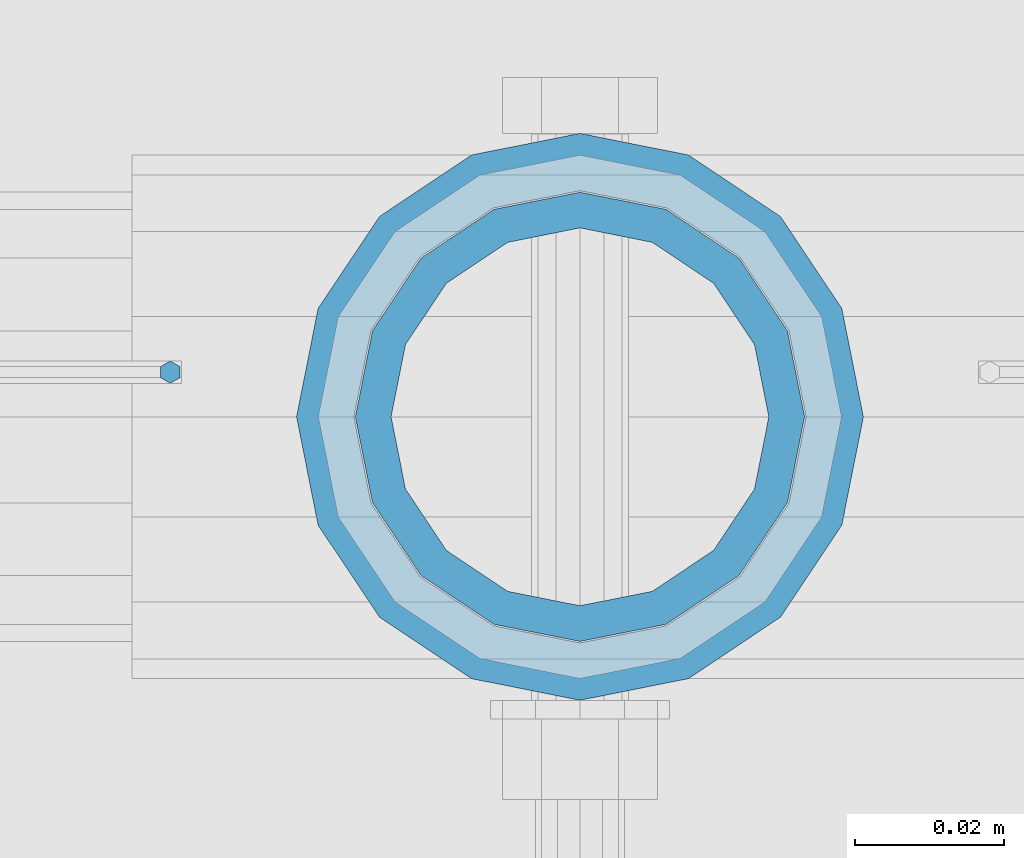
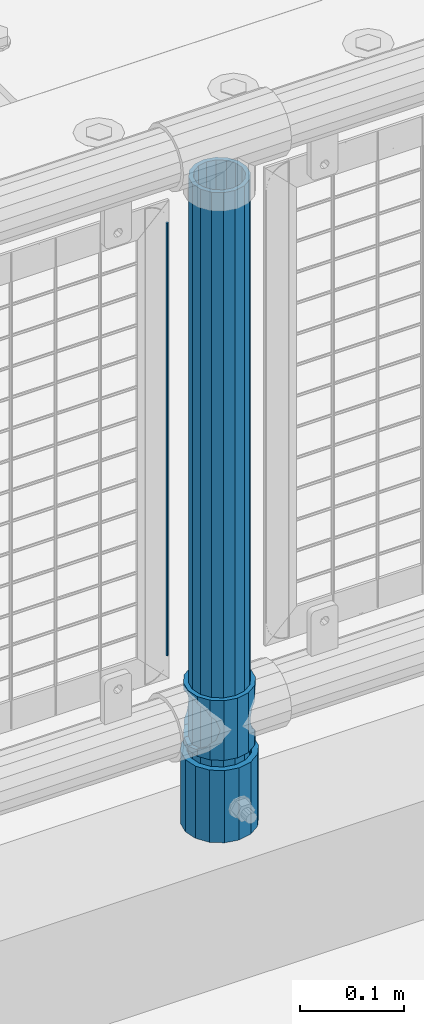
# One storey, part 67 of 208: 4 columns.
"""IFC2X3 building model written with IfcOpenShell, lengths in millimetres."""

from ifc_helpers import new_model, si_unit, frame, origin_with_axes, place, context, subcontext, project, spatial, faceted_brep, material, type_object, element, save


model = new_model("IFC2X3")

# Units and contexts
model_context = context("Model", 3, precision=1e-05, world=origin_with_axes())
body_context = subcontext(model_context, "Body", "Model", "MODEL_VIEW")
ifc_project = project(units=[si_unit("LENGTHUNIT", "METRE", prefix="MILLI"), si_unit("AREAUNIT", "SQUARE_METRE"), si_unit("VOLUMEUNIT", "CUBIC_METRE"), si_unit("MASSUNIT", "GRAM", prefix="KILO"), si_unit("TIMEUNIT", "SECOND"), si_unit("PLANEANGLEUNIT", "RADIAN"), si_unit("SOLIDANGLEUNIT", "STERADIAN"), si_unit("THERMODYNAMICTEMPERATUREUNIT", "DEGREE_CELSIUS"), si_unit("LUMINOUSINTENSITYUNIT", "LUMEN")], contexts=[model_context])

# Site, building, storey
site_placement = place(None, origin_with_axes())
site = spatial("IfcSite", under=ifc_project, at=site_placement, CompositionType="ELEMENT")
building_placement = place(site_placement, origin_with_axes())
building = spatial("IfcBuilding", under=site, at=building_placement, Name="Standard", CompositionType="ELEMENT")
storey_placement = place(building_placement, origin_with_axes())
storey = spatial("IfcBuildingStorey", under=building, at=storey_placement, Name="Undefined", CompositionType="ELEMENT", Elevation=0.0)

# Columns
ifc_material_1 = material()
column_type_1 = type_object("IfcColumnType", PredefinedType="NOTDEFINED")
column_1_placement = place(storey_placement, frame((-35429.0, 4664.5, 168.02), z_axis=(0.0, 1.0, 0.0), x_axis=(0.0, 0.0, 1.0)))
element("IfcColumn", 1, at=column_1_placement, inside=storey, type_object=column_type_1, material=ifc_material_1, context=body_context, shape_type="Brep", body=[
    faceted_brep([(0.0, -31.75, 0.0), (0.0, -29.3331751572332, 12.1501989775916), (85.0, -29.3331751572332, 12.1501989775916), (85.0, -31.75, 0.0), (0.0, -22.4506403026717, 22.4506403026726), (85.0, -22.4506403026717, 22.4506403026726), (0.0, -12.1501989775934, 29.3331751572332), (85.0, -12.1501989775934, 29.3331751572332), (0.0, 0.0, 31.75), (85.0, 0.0, 31.75), (0.0, 12.1501989775934, 29.3331751572332), (85.0, 12.1501989775934, 29.3331751572332), (0.0, 22.4506403026717, 22.4506403026726), (85.0, 22.4506403026717, 22.4506403026726), (0.0, 29.3331751572332, 12.1501989775916), (85.0, 29.3331751572332, 12.1501989775916), (0.0, 31.75, 0.0), (85.0, 31.75, 0.0), (0.0, 29.3331751572332, -12.1501989775916), (85.0, 29.3331751572332, -12.1501989775916), (0.0, 22.4506403026717, -22.4506403026726), (85.0, 22.4506403026717, -22.4506403026726), (0.0, 12.1501989775934, -29.3331751572332), (85.0, 12.1501989775934, -29.3331751572332), (0.0, 0.0, -31.75), (85.0, 0.0, -31.75), (0.0, -12.1501989775934, -29.3331751572332), (85.0, -12.1501989775934, -29.3331751572332), (0.0, -22.4506403026717, -22.4506403026726), (85.0, -22.4506403026717, -22.4506403026726), (0.0, -29.3331751572332, -12.1501989775916), (85.0, -29.3331751572332, -12.1501989775916), (0.0, -38.0499999999993, 0.0), (0.0, -35.1536162120537, -14.5611046014919), (85.0, -35.1536162120537, -14.5611046014919), (85.0, -38.0499999999993, 0.0), (0.0, -26.9054130241493, -26.9054130241484), (85.0, -26.9054130241493, -26.9054130241484), (0.0, -14.5611046014928, -35.1536162120547), (85.0, -14.5611046014928, -35.1536162120547), (0.0, 0.0, -38.0500000000002), (85.0, 0.0, -38.0500000000002), (0.0, 14.5611046014928, -35.1536162120547), (85.0, 14.5611046014928, -35.1536162120547), (0.0, 26.9054130241493, -26.9054130241484), (85.0, 26.9054130241493, -26.9054130241484), (0.0, 35.1536162120537, -14.5611046014919), (85.0, 35.1536162120537, -14.5611046014919), (0.0, 38.0499999999993, 0.0), (85.0, 38.0499999999993, 0.0), (0.0, 35.1536162120537, 14.5611046014919), (85.0, 35.1536162120537, 14.5611046014919), (0.0, 26.9054130241493, 26.9054130241484), (85.0, 26.9054130241493, 26.9054130241484), (0.0, 14.5611046014928, 35.1536162120547), (85.0, 14.5611046014928, 35.1536162120547), (0.0, 0.0, 38.0500000000002), (85.0, 0.0, 38.0500000000002), (0.0, -14.5611046014928, 35.1536162120547), (85.0, -14.5611046014928, 35.1536162120547), (0.0, -26.9054130241493, 26.9054130241484), (85.0, -26.9054130241493, 26.9054130241484), (0.0, -35.1536162120537, 14.5611046014919), (85.0, -35.1536162120537, 14.5611046014919)], [[[0, 1, 2, 3]], [[1, 4, 5, 2]], [[4, 6, 7, 5]], [[6, 8, 9, 7]], [[8, 10, 11, 9]], [[10, 12, 13, 11]], [[12, 14, 15, 13]], [[14, 16, 17, 15]], [[16, 18, 19, 17]], [[18, 20, 21, 19]], [[20, 22, 23, 21]], [[22, 24, 25, 23]], [[24, 26, 27, 25]], [[26, 28, 29, 27]], [[28, 30, 31, 29]], [[30, 0, 3, 31]], [[32, 33, 34, 35]], [[33, 36, 37, 34]], [[36, 38, 39, 37]], [[38, 40, 41, 39]], [[40, 42, 43, 41]], [[42, 44, 45, 43]], [[44, 46, 47, 45]], [[46, 48, 49, 47]], [[48, 50, 51, 49]], [[50, 52, 53, 51]], [[52, 54, 55, 53]], [[54, 56, 57, 55]], [[56, 58, 59, 57]], [[58, 60, 61, 59]], [[60, 62, 63, 61]], [[62, 32, 35, 63]], [[37, 39, 41, 43, 45, 47, 49, 51, 53, 55, 57, 59, 61, 63, 35, 34], [5, 7, 9, 11, 13, 15, 17, 19, 21, 23, 25, 27, 29, 31, 3, 2]], [[62, 60, 58, 56, 54, 52, 50, 48, 46, 44, 42, 40, 38, 36, 33, 32], [30, 28, 26, 24, 22, 20, 18, 16, 14, 12, 10, 8, 6, 4, 1, 0]]]),
])
ifc_material_2 = material(Name="Misc_Undefined")
column_type_2 = type_object("IfcColumnType", PredefinedType="NOTDEFINED")
column_2_placement = place(storey_placement, frame((-35429.0, 4664.5, 263.02), z_axis=(-1.0, 0.0, 0.0), x_axis=(0.0, 0.0, 1.0)))
element("IfcColumn", 2, at=column_2_placement, inside=storey, type_object=column_type_2, material=ifc_material_2, context=body_context, shape_type="Brep", body=[
    faceted_brep([(63.1897438117172, 11.6144421722802, -32.8397438117245), (63.1897438117172, 11.6144421722802, -28.0397438117143), (56.6106908090114, 21.4606908090118, -21.4606908090136), (56.6106908090114, 21.4606908090118, -27.1226768591077), (61.962379517676, 13.4513226476329, -32.4743655677739), (46.7644421722801, 28.0397438117179, -11.6144421722784), (46.7644421722801, 28.0397438117179, -20.0882031229921), (51.531042408003, 24.8548033587067, -24.8548033587067), (35.1500000000015, 30.35, 0.0), (35.1499999999996, 30.3500000000004, -16.6306603983685), (23.5355578277192, 28.0397438117179, -11.6144421722784), (23.5355578277192, 28.0397438117179, -20.0882031229921), (18.7689575919962, 24.8548033587067, -24.8548033587067), (13.6893091909879, 21.4606908090118, -21.4606908090136), (13.6893091909879, 21.4606908090118, -27.1226768591077), (8.33762048232325, 13.4513226476329, -32.4743655677739), (7.11025618828211, 11.6144421722802, -28.0397438117143), (7.11025618828211, 11.6144421722802, -32.8397438117245), (4.79999999999961, 0.0, -30.3499999999985), (4.79999999999961, 0.0, -35.1500000000015), (7.11025618828205, -11.6144421722802, -28.0397438117143), (7.11025618828205, -11.6144421722802, -32.8397438117245), (13.6893091909879, -21.4606908090118, -21.4606908090136), (13.6893091909879, -21.4606908090118, -27.1226768591005), (8.33762048232325, -13.4513226476329, -32.4743655677739), (23.5355578277191, -28.0397438117179, -11.6144421722784), (23.5355578277191, -28.0397438117179, -20.0882031229921), (18.7689575919962, -24.8548033587067, -24.8548033587067), (35.1500000000015, -30.35, 0.0), (35.1499999999996, -30.3500000000004, -16.6306603983685), (46.7644421722801, -28.0397438117179, -11.6144421722784), (46.7644421722801, -28.0397438117179, -20.0882031229921), (51.531042408003, -24.8548033587067, -24.8548033587067), (56.6106908090114, -21.4606908090118, -21.4606908090136), (56.6106908090114, -21.4606908090118, -27.1226768591005), (61.962379517675, -13.4513226476329, -32.4743655677739), (63.1897438117172, -11.6144421722802, -28.0397438117143), (63.1897438117172, -11.6144421722802, -32.8397438117245), (65.4999999999997, 0.0, -30.3499999999985), (65.4999999999997, 0.0, -35.1500000000015), (0.0, -28.0397438117179, -11.6144421722784), (0.0, -30.3500000000004, 0.0), (0.0, -21.4606908090118, -21.4606908090136), (0.0, -11.6144421722802, -28.0397438117143), (0.0, 0.0, -30.3499999999985), (0.0, 11.6144421722802, -28.0397438117143), (0.0, 21.4606908090118, -21.4606908090136), (0.0, 28.0397438117179, -11.6144421722784), (0.0, 30.3500000000004, 0.0), (0.0, 28.0397438117179, 11.6144421722784), (23.5355578277192, 28.0397438117179, 11.6144421722784), (0.0, 21.4606908090118, 21.4606908090136), (13.6893091909879, 21.4606908090118, 21.4606908090136), (0.0, 11.6144421722802, 28.0397438117143), (7.11025618828211, 11.6144421722802, 28.0397438117143), (0.0, 0.0, 30.3499999999985), (4.79999999999961, 0.0, 30.3499999999985), (0.0, -11.6144421722802, 28.0397438117143), (7.11025618828205, -11.6144421722802, 28.0397438117143), (0.0, -21.4606908090118, 21.4606908090136), (13.6893091909879, -21.4606908090118, 21.4606908090136), (0.0, -28.0397438117179, 11.6144421722784), (23.5355578277191, -28.0397438117179, 11.6144421722784), (0.0, -32.4743655677721, 13.4513226476338), (0.0, -35.1499999999996, 0.0), (70.2999999999993, -35.1499999999996, 0.0), (70.2999999999993, -32.4743655677721, 13.4513226476338), (0.0, 13.4513226476329, -32.4743655677739), (0.0, 24.8548033587067, -24.8548033587067), (0.0, 0.0, -35.1499999999996), (0.0, -13.4513226476329, -32.4743655677739), (0.0, -24.8548033587067, -24.8548033587067), (0.0, -24.8548033587067, 24.8548033587067), (0.0, -13.4513226476329, 32.4743655677739), (0.0, 0.0, 35.1499999999996), (0.0, 13.4513226476329, 32.4743655677739), (0.0, 24.8548033587067, 24.8548033587067), (0.0, 32.4743655677721, 13.4513226476338), (0.0, 35.1499999999996, 0.0), (0.0, 32.4743655677721, -13.4513226476338), (0.0, -32.4743655677721, -13.4513226476338), (70.2999999999993, 32.4743655677721, 13.4513226476338), (70.2999999999993, 35.1499999999996, 0.0), (70.2999999999993, 32.4743655677721, -13.4513226476338), (70.2999999999993, 24.8548033587067, -24.8548033587067), (70.2999999999993, 13.4513226476329, -32.4743655677739), (70.2999999999993, 0.0, -35.1500000000015), (70.2999999999993, -13.4513226476329, -32.4743655677739), (70.2999999999993, -24.8548033587067, -24.8548033587067), (70.2999999999993, -32.4743655677721, -13.4513226476338), (70.2999999999993, 28.0397438117179, 11.6144421722784), (70.2999999999993, 21.4606908090118, 21.4606908090136), (56.6106908090114, 21.4606908090118, 21.4606908090136), (46.7644421722801, 28.0397438117179, 11.6144421722784), (70.2999999999993, 11.6144421722802, 28.0397438117143), (63.1897438117172, 11.6144421722802, 28.0397438117143), (70.2999999999993, 0.0, 30.3499999999985), (65.4999999999997, 0.0, 30.3499999999985), (70.2999999999993, -11.6144421722802, 28.0397438117143), (63.1897438117172, -11.6144421722802, 28.0397438117143), (70.2999999999993, -21.4606908090118, 21.4606908090136), (56.6106908090114, -21.4606908090118, 21.4606908090136), (70.2999999999993, -28.0397438117179, 11.6144421722784), (46.7644421722801, -28.0397438117179, 11.6144421722784), (70.2999999999993, -11.6144421722802, -28.0397438117143), (70.2999999999993, 0.0, -30.3499999999985), (70.2999999999993, -21.4606908090118, -21.4606908090136), (70.2999999999993, -28.0397438117179, -11.6144421722784), (70.2999999999993, -30.3500000000004, 0.0), (70.2999999999993, 24.8548033587067, 24.8548033587067), (70.2999999999993, 13.4513226476329, 32.4743655677739), (70.2999999999993, 0.0, 35.1500000000015), (70.2999999999993, -13.4513226476329, 32.4743655677739), (70.2999999999993, -24.8548033587067, 24.8548033587067), (70.2999999999993, 30.3500000000004, 0.0), (70.2999999999993, 28.0397438117179, -11.6144421722784), (70.2999999999993, 21.4606908090118, -21.4606908090136), (70.2999999999993, 11.6144421722802, -28.0397438117143), (61.9623795176756, 13.4513226476329, 32.4743655677739), (51.531042408003, 24.8548033587067, 24.8548033587067), (56.6106908090114, 21.4606908090118, 27.1226768591005), (65.4999999999997, 0.0, 35.1500000000015), (63.1897438117172, 11.6144421722802, 32.8397438117172), (63.1897438117172, -11.6144421722802, 32.8397438117245), (61.962379517675, -13.4513226476329, 32.4743655677739), (56.6106908090114, -21.4606908090118, 27.1226768591077), (51.531042408003, -24.8548033587067, 24.8548033587067), (18.7689575919962, -24.8548033587067, 24.8548033587067), (46.7644421722801, -28.0397438117179, 20.0882031229776), (35.1499999999996, -30.3500000000004, 16.6306603983612), (23.5355578277191, -28.0397438117179, 20.0882031229776), (8.3376204823237, -13.4513226476329, 32.4743655677739), (13.6893091909879, -21.4606908090118, 27.1226768591077), (4.79999999999961, 0.0, 35.1500000000015), (7.11025618828205, -11.6144421722802, 32.8397438117245), (7.11025618828211, 11.6144421722802, 32.8397438117172), (8.3376204823237, 13.4513226476329, 32.4743655677739), (13.6893091909879, 21.4606908090118, 27.1226768591005), (18.7689575919962, 24.8548033587067, 24.8548033587067), (23.5355578277192, 28.0397438117179, 20.0882031229921), (35.1499999999996, 30.3500000000004, 16.6306603983685), (46.7644421722801, 28.0397438117179, 20.0882031229921)], [[[0, 1, 2, 3, 4]], [[3, 2, 5, 6, 7]], [[6, 5, 8, 9]], [[9, 8, 10, 11]], [[12, 11, 10, 13, 14]], [[15, 14, 13, 16, 17]], [[17, 16, 18, 19]], [[19, 18, 20, 21]], [[21, 20, 22, 23, 24]], [[23, 22, 25, 26, 27]], [[26, 25, 28, 29]], [[29, 28, 30, 31]], [[32, 31, 30, 33, 34]], [[35, 34, 33, 36, 37]], [[37, 36, 38, 39]], [[39, 38, 1, 0]], [[40, 41, 28, 25]], [[42, 40, 25, 22]], [[43, 42, 22, 20]], [[44, 43, 20, 18]], [[45, 44, 18, 16]], [[46, 45, 16, 13]], [[47, 46, 13, 10]], [[48, 47, 10, 8]], [[49, 48, 8, 50]], [[51, 49, 50, 52]], [[53, 51, 52, 54]], [[55, 53, 54, 56]], [[57, 55, 56, 58]], [[59, 57, 58, 60]], [[61, 59, 60, 62]], [[41, 61, 62, 28]], [[63, 64, 65, 66]], [[67, 68, 12, 14, 15]], [[69, 67, 15, 17, 19]], [[24, 70, 69, 19, 21]], [[27, 71, 70, 24, 23]], [[63, 72, 73, 74, 75, 76, 77, 78, 79, 68, 67, 69, 70, 71, 80, 64], [40, 42, 43, 44, 45, 46, 47, 48, 49, 51, 53, 55, 57, 59, 61, 41]], [[78, 77, 81, 82]], [[79, 78, 82, 83]], [[9, 11, 12, 68, 79, 83, 84, 7, 6]], [[7, 84, 85, 4, 3]], [[4, 85, 86, 39, 0]], [[87, 88, 32, 34, 35]], [[86, 87, 35, 37, 39]], [[88, 89, 80, 71, 27, 26, 29, 31, 32]], [[64, 80, 89, 65]], [[90, 91, 92, 93]], [[91, 94, 95, 92]], [[94, 96, 97, 95]], [[96, 98, 99, 97]], [[98, 100, 101, 99]], [[100, 102, 103, 101]], [[104, 105, 38, 36]], [[106, 104, 36, 33]], [[107, 106, 33, 30]], [[108, 107, 30, 28]], [[102, 108, 28, 103]], [[88, 87, 86, 85, 84, 83, 82, 81, 109, 110, 111, 112, 113, 66, 65, 89], [100, 98, 96, 94, 91, 90, 114, 115, 116, 117, 105, 104, 106, 107, 108, 102]], [[118, 110, 109, 119, 120]], [[121, 111, 110, 118, 122]], [[112, 111, 121, 123, 124]], [[113, 112, 124, 125, 126]], [[127, 72, 63, 66, 113, 126, 128, 129, 130]], [[131, 73, 72, 127, 132]], [[133, 74, 73, 131, 134]], [[75, 74, 133, 135, 136]], [[76, 75, 136, 137, 138]], [[119, 109, 81, 77, 76, 138, 139, 140, 141]], [[92, 120, 119, 141, 93]], [[95, 122, 118, 120, 92]], [[97, 121, 122, 95]], [[99, 123, 121, 97]], [[101, 125, 124, 123, 99]], [[103, 128, 126, 125, 101]], [[28, 129, 128, 103]], [[62, 130, 129, 28]], [[60, 132, 127, 130, 62]], [[58, 134, 131, 132, 60]], [[56, 133, 134, 58]], [[54, 135, 133, 56]], [[52, 137, 136, 135, 54]], [[50, 139, 138, 137, 52]], [[8, 140, 139, 50]], [[93, 141, 140, 8]], [[114, 90, 93, 8]], [[115, 114, 8, 5]], [[116, 115, 5, 2]], [[117, 116, 2, 1]], [[105, 117, 1, 38]]]),
])
column_type_3 = type_object("IfcColumnType", PredefinedType="NOTDEFINED")
column_3_placement = place(storey_placement, frame((-35429.0, 4664.5, 168.02), z_axis=(-1.0, 0.0, 0.0), x_axis=(0.0, 0.0, 1.0)))
element("IfcColumn", 3, at=column_3_placement, inside=storey, type_object=column_type_3, material=ifc_material_1, context=body_context, shape_type="Brep", body=[
    faceted_brep([(0.0, -25.3500000000004, 0.0), (0.0, -23.4203461491616, 9.70102501045403), (760.0, -23.4203461491616, 9.70102501045403), (760.0, -25.3500000000004, 0.0), (0.0, -17.9251569030794, 17.9251569030785), (760.0, -17.9251569030794, 17.9251569030785), (0.0, -9.70102501045494, 23.4203461491597), (760.0, -9.70102501045494, 23.4203461491597), (0.0, 0.0, 25.3499999999985), (760.0, 0.0, 25.3499999999985), (0.0, 9.70102501045494, 23.4203461491597), (760.0, 9.70102501045494, 23.4203461491597), (0.0, 17.9251569030794, 17.9251569030785), (760.0, 17.9251569030794, 17.9251569030785), (0.0, 23.4203461491616, 9.70102501045403), (760.0, 23.4203461491616, 9.70102501045403), (0.0, 25.3500000000004, 0.0), (760.0, 25.3500000000004, 0.0), (0.0, 23.4203461491616, -9.70102501045403), (760.0, 23.4203461491616, -9.70102501045403), (0.0, 17.9251569030794, -17.9251569030785), (760.0, 17.9251569030794, -17.9251569030785), (0.0, 9.70102501045494, -23.4203461491597), (760.0, 9.70102501045494, -23.4203461491597), (0.0, 0.0, -25.3499999999985), (760.0, 0.0, -25.3499999999985), (0.0, -9.70102501045494, -23.4203461491597), (760.0, -9.70102501045494, -23.4203461491597), (0.0, -17.9251569030794, -17.9251569030785), (760.0, -17.9251569030794, -17.9251569030785), (0.0, -23.4203461491616, -9.70102501045403), (760.0, -23.4203461491616, -9.70102501045403), (0.0, -30.1499999999996, 0.0), (0.0, -27.8549679052148, -11.5379054858058), (760.0, -27.8549679052148, -11.5379054858058), (760.0, -30.1499999999996, 0.0), (0.0, -21.3192694527743, -21.3192694527752), (760.0, -21.3192694527743, -21.3192694527752), (0.0, -11.5379054858076, -27.8549679052157), (760.0, -11.5379054858076, -27.8549679052157), (0.0, 0.0, -30.1500000000015), (760.0, 0.0, -30.1500000000015), (0.0, 11.5379054858076, -27.8549679052157), (760.0, 11.5379054858076, -27.8549679052157), (0.0, 21.3192694527743, -21.3192694527752), (760.0, 21.3192694527743, -21.3192694527752), (0.0, 27.8549679052157, -11.5379054858058), (760.0, 27.8549679052157, -11.5379054858058), (0.0, 30.1499999999996, 0.0), (760.0, 30.1499999999996, 0.0), (0.0, 27.8549679052157, 11.5379054858058), (760.0, 27.8549679052157, 11.5379054858058), (0.0, 21.3192694527743, 21.3192694527752), (760.0, 21.3192694527743, 21.3192694527752), (0.0, 11.5379054858076, 27.8549679052157), (760.0, 11.5379054858076, 27.8549679052157), (0.0, 0.0, 30.1500000000015), (760.0, 0.0, 30.1500000000015), (0.0, -11.5379054858076, 27.8549679052157), (760.0, -11.5379054858076, 27.8549679052157), (0.0, -21.3192694527743, 21.3192694527752), (760.0, -21.3192694527743, 21.3192694527752), (0.0, -27.8549679052157, 11.5379054858058), (760.0, -27.8549679052157, 11.5379054858058)], [[[0, 1, 2, 3]], [[1, 4, 5, 2]], [[4, 6, 7, 5]], [[6, 8, 9, 7]], [[8, 10, 11, 9]], [[10, 12, 13, 11]], [[12, 14, 15, 13]], [[14, 16, 17, 15]], [[16, 18, 19, 17]], [[18, 20, 21, 19]], [[20, 22, 23, 21]], [[22, 24, 25, 23]], [[24, 26, 27, 25]], [[26, 28, 29, 27]], [[28, 30, 31, 29]], [[30, 0, 3, 31]], [[32, 33, 34, 35]], [[33, 36, 37, 34]], [[36, 38, 39, 37]], [[38, 40, 41, 39]], [[40, 42, 43, 41]], [[42, 44, 45, 43]], [[44, 46, 47, 45]], [[46, 48, 49, 47]], [[48, 50, 51, 49]], [[50, 52, 53, 51]], [[52, 54, 55, 53]], [[54, 56, 57, 55]], [[56, 58, 59, 57]], [[58, 60, 61, 59]], [[60, 62, 63, 61]], [[62, 32, 35, 63]], [[37, 39, 41, 43, 45, 47, 49, 51, 53, 55, 57, 59, 61, 63, 35, 34], [5, 7, 9, 11, 13, 15, 17, 19, 21, 23, 25, 27, 29, 31, 3, 2]], [[62, 60, 58, 56, 54, 52, 50, 48, 46, 44, 42, 40, 38, 36, 33, 32], [30, 28, 26, 24, 22, 20, 18, 16, 14, 12, 10, 8, 6, 4, 1, 0]]]),
])
column_type_4 = type_object("IfcColumnType", Name="D3", PredefinedType="NOTDEFINED")
column_4_placement = place(storey_placement, frame((-35484.0, 4670.5, 378.020000000001), z_axis=(-1.0, 0.0, 0.0), x_axis=(0.0, 0.0, 1.0)))
element("IfcColumn", 4, at=column_4_placement, inside=storey, type_object=column_type_4, material=ifc_material_2, ObjectType="D3", context=body_context, shape_type="Brep", body=[
    faceted_brep([(0.0, -1.49999999999909, 3.63797880709171e-12), (-7.27595761418343e-12, -0.749999999999091, -1.29903810567669), (510.0, -0.75, -1.29903810567703), (510.0, -1.5, 0.0), (-3.63797880709171e-12, 0.750000000000909, -1.29903810567669), (510.0, 0.75, -1.29903810567703), (0.0, 1.50000000000182, 3.63797880709171e-12), (510.0, 1.5, 0.0), (-3.63797880709171e-12, 0.750000000000909, 1.29903810567669), (510.0, 0.75, 1.29903810567703), (-7.27595761418343e-12, -0.749999999999091, 1.29903810567669), (510.0, -0.75, 1.29903810567703)], [[[0, 1, 2, 3]], [[1, 4, 5, 2]], [[4, 6, 7, 5]], [[6, 8, 9, 7]], [[8, 10, 11, 9]], [[10, 0, 3, 11]], [[5, 7, 9, 11, 3, 2]], [[10, 8, 6, 4, 1, 0]]]),
])

save(model, "model.ifc")
